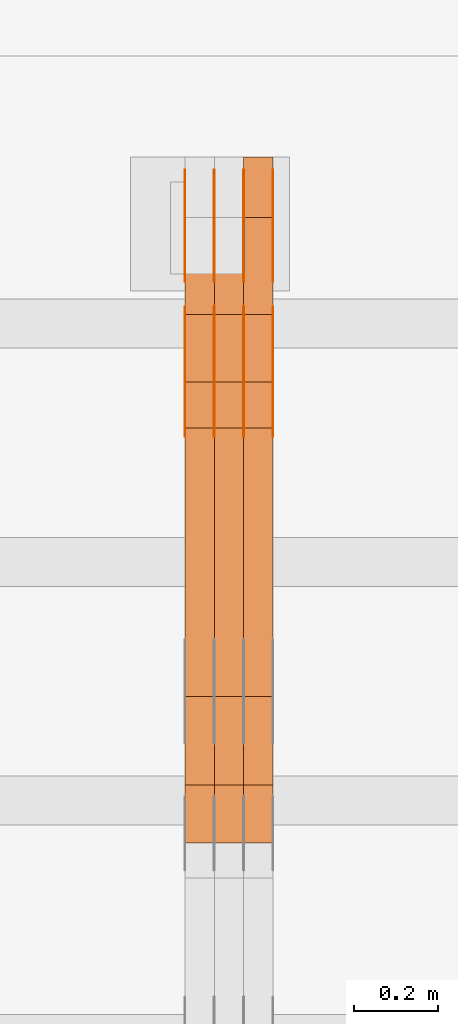
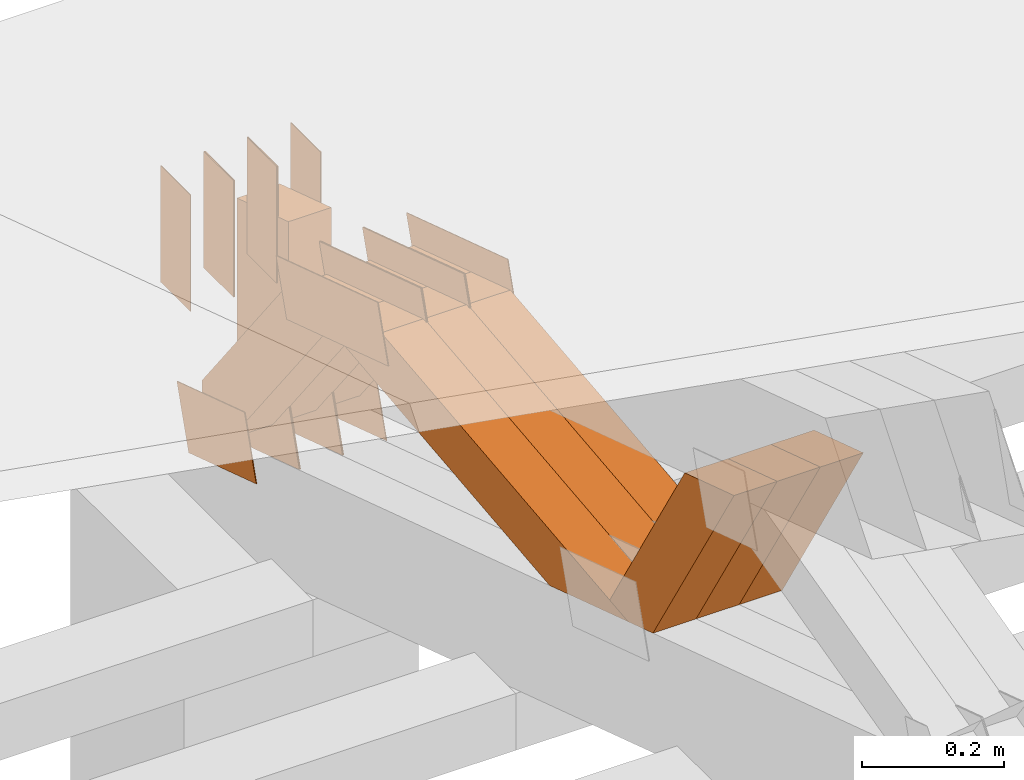
# One storey, part 222 of 385: 28 proxies.
"""IFC2X3 building model written with IfcOpenShell, lengths in millimetres."""

from ifc_helpers import new_model, entity, si_unit, converted_unit, derived_unit, direction, frame, frame_2d, origin, place, context, subcontext, project, spatial, polyline, rectangle, outline, extrude, source, transform, mapped, material, type_object, type_shapes, element, save


model = new_model("IFC2X3")

# Units and contexts
model_context = context("Model", 3, precision=0.01, world=origin(), true_north=direction((6.12303176911189e-17, 1.0)))
body_context = subcontext(model_context, "Body", "Model", "MODEL_VIEW")
ifc_project = project(units=[si_unit("LENGTHUNIT", "METRE", prefix="MILLI"), si_unit("AREAUNIT", "SQUARE_METRE"), si_unit("VOLUMEUNIT", "CUBIC_METRE"), converted_unit("PLANEANGLEUNIT", "DEGREE", entity("IfcRatioMeasure", 0.0174532925199433), si_unit("PLANEANGLEUNIT", "RADIAN"), dimensions=[0, 0, 0, 0, 0, 0, 0]), si_unit("MASSUNIT", "GRAM", prefix="KILO"), derived_unit("MASSDENSITYUNIT", [(si_unit("MASSUNIT", "GRAM", prefix="KILO"), 1), (si_unit("LENGTHUNIT", "METRE"), -3)]), si_unit("TIMEUNIT", "SECOND"), si_unit("FREQUENCYUNIT", "HERTZ"), si_unit("THERMODYNAMICTEMPERATUREUNIT", "DEGREE_CELSIUS"), derived_unit("THERMALTRANSMITTANCEUNIT", [(si_unit("MASSUNIT", "GRAM", prefix="KILO"), 1), (si_unit("THERMODYNAMICTEMPERATUREUNIT", "KELVIN"), -1), (si_unit("TIMEUNIT", "SECOND"), -3)]), derived_unit("VOLUMETRICFLOWRATEUNIT", [(si_unit("LENGTHUNIT", "METRE"), 3), (si_unit("TIMEUNIT", "SECOND"), -1)]), si_unit("ELECTRICCURRENTUNIT", "AMPERE"), si_unit("ELECTRICVOLTAGEUNIT", "VOLT"), si_unit("POWERUNIT", "WATT"), si_unit("FORCEUNIT", "NEWTON", prefix="KILO"), si_unit("ILLUMINANCEUNIT", "LUX"), si_unit("LUMINOUSFLUXUNIT", "LUMEN"), si_unit("LUMINOUSINTENSITYUNIT", "CANDELA"), derived_unit("USERDEFINED", [(si_unit("MASSUNIT", "GRAM", prefix="KILO"), -1), (si_unit("LENGTHUNIT", "METRE"), -2), (si_unit("TIMEUNIT", "SECOND"), 3), (si_unit("LUMINOUSFLUXUNIT", "LUMEN"), 1)]), derived_unit("LINEARVELOCITYUNIT", [(si_unit("LENGTHUNIT", "METRE"), 1), (si_unit("TIMEUNIT", "SECOND"), -1)]), si_unit("PRESSUREUNIT", "PASCAL"), derived_unit("USERDEFINED", [(si_unit("LENGTHUNIT", "METRE"), -2), (si_unit("MASSUNIT", "GRAM", prefix="KILO"), 1), (si_unit("TIMEUNIT", "SECOND"), -2)])], contexts=[model_context])

# Site, building, storey
site_placement = place(None, origin())
site = spatial("IfcSite", under=ifc_project, at=site_placement, CompositionType="ELEMENT")
building_placement = place(site_placement, origin())
building = spatial("IfcBuilding", under=site, at=building_placement, CompositionType="ELEMENT")
storey_placement = place(building_placement, origin())
storey = spatial("IfcBuildingStorey", under=building, at=storey_placement, Name="Default", CompositionType="ELEMENT", Elevation=0.0)

# Proxies
ifc_material_1 = material(Name="IfcSurfaceStyle #274926")
building_element_proxy_type_1 = type_object("IfcBuildingElementProxyType", PredefinedType="NOTDEFINED", material=ifc_material_1)
shared_shape_1 = source(origin(), body_context, "Body", "SweptSolid", [
    extrude(outline(polyline([(-100.000024997547, -54.0000105875654), (100.000088940899, -54.0000105875654), (99.9999100805868, 54.0000105875654), (-99.9999740239394, 54.0000105875654), (-100.000024997547, -54.0000105875654)])), frame((100.000088940899, 54.0000474633838, 0.0), z_axis=(0.0, 0.0, 1.0), x_axis=(-1.0, 0.0, 0.0)), (0.0, 0.0, 1.0), 1.3),
])
type_shapes(building_element_proxy_type_1, [shared_shape_1])
proxy_1_placement = place(building_placement, frame((21386.3, 26390.6212638563, 73.3227520411355), z_axis=(-1.0, 0.0, 0.0), x_axis=(0.0, -0.951056516295124, 0.309016994375039)))
element("IfcBuildingElementProxy", 1, at=proxy_1_placement, inside=storey, type_object=building_element_proxy_type_1, material=ifc_material_1, context=body_context, shape_type="MappedRepresentation", body=[
    mapped(shared_shape_1, transform((0.0, 0.0, 0.0), scale=1.0)),
])
ifc_material_2 = material(Name="IfcSurfaceStyle #274869")
building_element_proxy_type_2 = type_object("IfcBuildingElementProxyType", PredefinedType="NOTDEFINED", material=ifc_material_2)
shared_shape_2 = source(origin(), body_context, "Body", "SweptSolid", [
    extrude(outline(polyline([(-100.000024997547, -54.0000105875654), (100.000088940899, -54.0000105875654), (99.9999100805868, 54.0000105875654), (-99.9999740239394, 54.0000105875654), (-100.000024997547, -54.0000105875654)])), frame((100.000088940899, 54.0000474633838, 0.0), z_axis=(0.0, 0.0, 1.0), x_axis=(-1.0, 0.0, 0.0)), (0.0, 0.0, 1.0), 1.3),
])
type_shapes(building_element_proxy_type_2, [shared_shape_2])
proxy_2_placement = place(building_placement, frame((21315.0, 26390.6212638563, 73.3227520411355), z_axis=(-1.0, 0.0, 0.0), x_axis=(0.0, -0.951056516295124, 0.309016994375039)))
element("IfcBuildingElementProxy", 2, at=proxy_2_placement, inside=storey, type_object=building_element_proxy_type_2, material=ifc_material_2, context=body_context, shape_type="MappedRepresentation", body=[
    mapped(shared_shape_2, transform((0.0, 0.0, 0.0), scale=1.0)),
])
ifc_material_3 = material(Name="IfcSurfaceStyle #274812")
building_element_proxy_type_3 = type_object("IfcBuildingElementProxyType", PredefinedType="NOTDEFINED", material=ifc_material_3)
shared_shape_3 = source(origin(), body_context, "Body", "SweptSolid", [
    extrude(outline(polyline([(-100.000024997547, -54.0000105875654), (100.000088940899, -54.0000105875654), (99.9999100805868, 54.0000105875654), (-99.9999740239394, 54.0000105875654), (-100.000024997547, -54.0000105875654)])), frame((100.000088940899, 54.0000474633838, 0.0), z_axis=(0.0, 0.0, 1.0), x_axis=(-1.0, 0.0, 0.0)), (0.0, 0.0, 1.0), 1.3),
])
type_shapes(building_element_proxy_type_3, [shared_shape_3])
proxy_3_placement = place(building_placement, frame((21316.3, 26390.6212638563, 73.3227520411355), z_axis=(-1.0, 0.0, 0.0), x_axis=(0.0, -0.951056516295124, 0.309016994375039)))
element("IfcBuildingElementProxy", 3, at=proxy_3_placement, inside=storey, type_object=building_element_proxy_type_3, material=ifc_material_3, context=body_context, shape_type="MappedRepresentation", body=[
    mapped(shared_shape_3, transform((0.0, 0.0, 0.0), scale=1.0)),
])
ifc_material_4 = material(Name="IfcSurfaceStyle #274755")
building_element_proxy_type_4 = type_object("IfcBuildingElementProxyType", PredefinedType="NOTDEFINED", material=ifc_material_4)
shared_shape_4 = source(origin(), body_context, "Body", "SweptSolid", [
    extrude(outline(polyline([(-100.000024997547, -54.0000105875654), (100.000088940899, -54.0000105875654), (99.9999100805868, 54.0000105875654), (-99.9999740239394, 54.0000105875654), (-100.000024997547, -54.0000105875654)])), frame((100.000088940899, 54.0000474633838, 0.0), z_axis=(0.0, 0.0, 1.0), x_axis=(-1.0, 0.0, 0.0)), (0.0, 0.0, 1.0), 1.29999999999998),
])
type_shapes(building_element_proxy_type_4, [shared_shape_4])
proxy_4_placement = place(building_placement, frame((21245.0, 26390.6212638563, 73.3227520411355), z_axis=(-1.0, 0.0, 0.0), x_axis=(0.0, -0.951056516295124, 0.309016994375039)))
element("IfcBuildingElementProxy", 4, at=proxy_4_placement, inside=storey, type_object=building_element_proxy_type_4, material=ifc_material_4, context=body_context, shape_type="MappedRepresentation", body=[
    mapped(shared_shape_4, transform((0.0, 0.0, 0.0), scale=1.0)),
])
ifc_material_5 = material(Name="IfcSurfaceStyle #274698")
building_element_proxy_type_5 = type_object("IfcBuildingElementProxyType", PredefinedType="NOTDEFINED", material=ifc_material_5)
shared_shape_5 = source(origin(), body_context, "Body", "SweptSolid", [
    extrude(outline(polyline([(-100.000024997547, -54.0000105875654), (100.000088940899, -54.0000105875654), (99.9999100805868, 54.0000105875654), (-99.9999740239394, 54.0000105875654), (-100.000024997547, -54.0000105875654)])), frame((100.000088940899, 54.0000474633838, 0.0), z_axis=(0.0, 0.0, 1.0), x_axis=(-1.0, 0.0, 0.0)), (0.0, 0.0, 1.0), 1.29999999999998),
])
type_shapes(building_element_proxy_type_5, [shared_shape_5])
proxy_5_placement = place(building_placement, frame((21246.3, 26390.6212638563, 73.3227520411355), z_axis=(-1.0, 0.0, 0.0), x_axis=(0.0, -0.951056516295124, 0.309016994375039)))
element("IfcBuildingElementProxy", 5, at=proxy_5_placement, inside=storey, type_object=building_element_proxy_type_5, material=ifc_material_5, context=body_context, shape_type="MappedRepresentation", body=[
    mapped(shared_shape_5, transform((0.0, 0.0, 0.0), scale=1.0)),
])
ifc_material_6 = material(Name="IfcSurfaceStyle #274641")
building_element_proxy_type_6 = type_object("IfcBuildingElementProxyType", PredefinedType="NOTDEFINED", material=ifc_material_6)
shared_shape_6 = source(origin(), body_context, "Body", "SweptSolid", [
    extrude(outline(polyline([(-100.000024997547, -54.0000105875654), (100.000088940899, -54.0000105875654), (99.9999100805868, 54.0000105875654), (-99.9999740239394, 54.0000105875654), (-100.000024997547, -54.0000105875654)])), frame((100.000088940899, 54.0000474633838, 0.0), z_axis=(0.0, 0.0, 1.0), x_axis=(-1.0, 0.0, 0.0)), (0.0, 0.0, 1.0), 1.29999999999999),
])
type_shapes(building_element_proxy_type_6, [shared_shape_6])
proxy_6_placement = place(building_placement, frame((21175.0, 26390.6212638563, 73.3227520411355), z_axis=(-1.0, 0.0, 0.0), x_axis=(0.0, -0.951056516295124, 0.309016994375039)))
element("IfcBuildingElementProxy", 6, at=proxy_6_placement, inside=storey, type_object=building_element_proxy_type_6, material=ifc_material_6, context=body_context, shape_type="MappedRepresentation", body=[
    mapped(shared_shape_6, transform((0.0, 0.0, 0.0), scale=1.0)),
])
ifc_material_7 = material(Name="IfcSurfaceStyle #262272")
building_element_proxy_type_7 = type_object("IfcBuildingElementProxyType", PredefinedType="NOTDEFINED", material=ifc_material_7)
shared_shape_7 = source(origin(), body_context, "Body", "SweptSolid", [
    extrude(outline(polyline([(-149.999901061401, -48.0000057587028), (150.000035297123, -48.0000057587028), (149.999910491851, 48.0000057587028), (-150.000044727574, 48.0000057587028), (-149.999901061401, -48.0000057587028)])), frame((150.000035297123, 48.0000632585775, 0.0), z_axis=(0.0, 0.0, 1.0), x_axis=(-1.0, 0.0, 0.0)), (0.0, 0.0, 1.0), 1.29999999999999),
])
type_shapes(building_element_proxy_type_7, [shared_shape_7])
proxy_7_placement = place(building_placement, frame((21386.3, 26115.0176968219, 469.58296924555), z_axis=(-1.0, 0.0, 0.0), x_axis=(0.0, -0.951056516295154, 0.309016994374948)))
element("IfcBuildingElementProxy", 7, at=proxy_7_placement, inside=storey, type_object=building_element_proxy_type_7, material=ifc_material_7, context=body_context, shape_type="MappedRepresentation", body=[
    mapped(shared_shape_7, transform((0.0, 0.0, 0.0), scale=1.0)),
])
ifc_material_8 = material(Name="IfcSurfaceStyle #262215")
building_element_proxy_type_8 = type_object("IfcBuildingElementProxyType", PredefinedType="NOTDEFINED", material=ifc_material_8)
shared_shape_8 = source(origin(), body_context, "Body", "SweptSolid", [
    extrude(outline(polyline([(-149.999901061401, -48.0000057587028), (150.000035297123, -48.0000057587028), (149.999910491851, 48.0000057587028), (-150.000044727574, 48.0000057587028), (-149.999901061401, -48.0000057587028)])), frame((150.000035297123, 48.0000632585775, 0.0), z_axis=(0.0, 0.0, 1.0), x_axis=(-1.0, 0.0, 0.0)), (0.0, 0.0, 1.0), 1.29999999999999),
])
type_shapes(building_element_proxy_type_8, [shared_shape_8])
proxy_8_placement = place(building_placement, frame((21315.0, 26115.0176968219, 469.58296924555), z_axis=(-1.0, 0.0, 0.0), x_axis=(0.0, -0.951056516295154, 0.309016994374948)))
element("IfcBuildingElementProxy", 8, at=proxy_8_placement, inside=storey, type_object=building_element_proxy_type_8, material=ifc_material_8, context=body_context, shape_type="MappedRepresentation", body=[
    mapped(shared_shape_8, transform((0.0, 0.0, 0.0), scale=1.0)),
])
ifc_material_9 = material(Name="IfcSurfaceStyle #262158")
building_element_proxy_type_9 = type_object("IfcBuildingElementProxyType", PredefinedType="NOTDEFINED", material=ifc_material_9)
shared_shape_9 = source(origin(), body_context, "Body", "SweptSolid", [
    extrude(outline(polyline([(-149.999901061401, -48.0000057587028), (150.000035297123, -48.0000057587028), (149.999910491851, 48.0000057587028), (-150.000044727574, 48.0000057587028), (-149.999901061401, -48.0000057587028)])), frame((150.000035297123, 48.0000632585775, 0.0), z_axis=(0.0, 0.0, 1.0), x_axis=(-1.0, 0.0, 0.0)), (0.0, 0.0, 1.0), 1.29999999999999),
])
type_shapes(building_element_proxy_type_9, [shared_shape_9])
proxy_9_placement = place(building_placement, frame((21316.3, 26115.0176968219, 469.58296924555), z_axis=(-1.0, 0.0, 0.0), x_axis=(0.0, -0.951056516295154, 0.309016994374948)))
element("IfcBuildingElementProxy", 9, at=proxy_9_placement, inside=storey, type_object=building_element_proxy_type_9, material=ifc_material_9, context=body_context, shape_type="MappedRepresentation", body=[
    mapped(shared_shape_9, transform((0.0, 0.0, 0.0), scale=1.0)),
])
ifc_material_10 = material(Name="IfcSurfaceStyle #262101")
building_element_proxy_type_10 = type_object("IfcBuildingElementProxyType", PredefinedType="NOTDEFINED", material=ifc_material_10)
shared_shape_10 = source(origin(), body_context, "Body", "SweptSolid", [
    extrude(outline(polyline([(-149.999901061401, -48.0000057587028), (150.000035297123, -48.0000057587028), (149.999910491851, 48.0000057587028), (-150.000044727574, 48.0000057587028), (-149.999901061401, -48.0000057587028)])), frame((150.000035297123, 48.0000632585775, 0.0), z_axis=(0.0, 0.0, 1.0), x_axis=(-1.0, 0.0, 0.0)), (0.0, 0.0, 1.0), 1.29999999999998),
])
type_shapes(building_element_proxy_type_10, [shared_shape_10])
proxy_10_placement = place(building_placement, frame((21245.0, 26115.0176968219, 469.58296924555), z_axis=(-1.0, 0.0, 0.0), x_axis=(0.0, -0.951056516295154, 0.309016994374948)))
element("IfcBuildingElementProxy", 10, at=proxy_10_placement, inside=storey, type_object=building_element_proxy_type_10, material=ifc_material_10, context=body_context, shape_type="MappedRepresentation", body=[
    mapped(shared_shape_10, transform((0.0, 0.0, 0.0), scale=1.0)),
])
ifc_material_11 = material(Name="IfcSurfaceStyle #262044")
building_element_proxy_type_11 = type_object("IfcBuildingElementProxyType", PredefinedType="NOTDEFINED", material=ifc_material_11)
shared_shape_11 = source(origin(), body_context, "Body", "SweptSolid", [
    extrude(outline(polyline([(-149.999901061401, -48.0000057587028), (150.000035297123, -48.0000057587028), (149.999910491851, 48.0000057587028), (-150.000044727574, 48.0000057587028), (-149.999901061401, -48.0000057587028)])), frame((150.000035297123, 48.0000632585775, 0.0), z_axis=(0.0, 0.0, 1.0), x_axis=(-1.0, 0.0, 0.0)), (0.0, 0.0, 1.0), 1.29999999999998),
])
type_shapes(building_element_proxy_type_11, [shared_shape_11])
proxy_11_placement = place(building_placement, frame((21246.3, 26115.0176968219, 469.58296924555), z_axis=(-1.0, 0.0, 0.0), x_axis=(0.0, -0.951056516295154, 0.309016994374948)))
element("IfcBuildingElementProxy", 11, at=proxy_11_placement, inside=storey, type_object=building_element_proxy_type_11, material=ifc_material_11, context=body_context, shape_type="MappedRepresentation", body=[
    mapped(shared_shape_11, transform((0.0, 0.0, 0.0), scale=1.0)),
])
ifc_material_12 = material(Name="IfcSurfaceStyle #261987")
building_element_proxy_type_12 = type_object("IfcBuildingElementProxyType", PredefinedType="NOTDEFINED", material=ifc_material_12)
shared_shape_12 = source(origin(), body_context, "Body", "SweptSolid", [
    extrude(outline(polyline([(-149.999901061401, -48.0000057587028), (150.000035297123, -48.0000057587028), (149.999910491851, 48.0000057587028), (-150.000044727574, 48.0000057587028), (-149.999901061401, -48.0000057587028)])), frame((150.000035297123, 48.0000632585775, 0.0), z_axis=(0.0, 0.0, 1.0), x_axis=(-1.0, 0.0, 0.0)), (0.0, 0.0, 1.0), 1.29999999999998),
])
type_shapes(building_element_proxy_type_12, [shared_shape_12])
proxy_12_placement = place(building_placement, frame((21175.0, 26115.0176968219, 469.58296924555), z_axis=(-1.0, 0.0, 0.0), x_axis=(0.0, -0.951056516295154, 0.309016994374948)))
element("IfcBuildingElementProxy", 12, at=proxy_12_placement, inside=storey, type_object=building_element_proxy_type_12, material=ifc_material_12, context=body_context, shape_type="MappedRepresentation", body=[
    mapped(shared_shape_12, transform((0.0, 0.0, 0.0), scale=1.0)),
])
ifc_material_13 = material(Name="IfcSurfaceStyle #261930")
building_element_proxy_type_13 = type_object("IfcBuildingElementProxyType", PredefinedType="NOTDEFINED", material=ifc_material_13)
shared_shape_13 = source(origin(), body_context, "Body", "SweptSolid", [
    extrude(rectangle(XDim=200.0, YDim=84.0000000000005, at=frame_2d((-2.1316282072803e-14, 1.06581410364015e-14), x_axis=(1.0, 0.0))), frame((100.0, 42.0, 0.0), z_axis=(0.0, 0.0, 1.0), x_axis=(-1.0, 0.0, 0.0)), (0.0, 0.0, 1.0), 1.3),
])
type_shapes(building_element_proxy_type_13, [shared_shape_13])
proxy_13_placement = place(building_placement, frame((21386.3, 26469.5000000002, 518.521545410156), z_axis=(-1.0, 0.0, 0.0), x_axis=(0.0, 0.0, -1.0)))
element("IfcBuildingElementProxy", 13, at=proxy_13_placement, inside=storey, type_object=building_element_proxy_type_13, material=ifc_material_13, context=body_context, shape_type="MappedRepresentation", body=[
    mapped(shared_shape_13, transform((0.0, 0.0, 0.0), scale=1.0)),
])
ifc_material_14 = material(Name="IfcSurfaceStyle #261873")
building_element_proxy_type_14 = type_object("IfcBuildingElementProxyType", PredefinedType="NOTDEFINED", material=ifc_material_14)
shared_shape_14 = source(origin(), body_context, "Body", "SweptSolid", [
    extrude(rectangle(XDim=200.0, YDim=84.0000000000005, at=frame_2d((-2.1316282072803e-14, 1.06581410364015e-14), x_axis=(1.0, 0.0))), frame((100.0, 42.0, 0.0), z_axis=(0.0, 0.0, 1.0), x_axis=(-1.0, 0.0, 0.0)), (0.0, 0.0, 1.0), 1.3),
])
type_shapes(building_element_proxy_type_14, [shared_shape_14])
proxy_14_placement = place(building_placement, frame((21315.0, 26469.5000000002, 518.521545410156), z_axis=(-1.0, 0.0, 0.0), x_axis=(0.0, 0.0, -1.0)))
element("IfcBuildingElementProxy", 14, at=proxy_14_placement, inside=storey, type_object=building_element_proxy_type_14, material=ifc_material_14, context=body_context, shape_type="MappedRepresentation", body=[
    mapped(shared_shape_14, transform((0.0, 0.0, 0.0), scale=1.0)),
])
ifc_material_15 = material(Name="IfcSurfaceStyle #261816")
building_element_proxy_type_15 = type_object("IfcBuildingElementProxyType", PredefinedType="NOTDEFINED", material=ifc_material_15)
shared_shape_15 = source(origin(), body_context, "Body", "SweptSolid", [
    extrude(rectangle(XDim=200.0, YDim=84.0000000000005, at=frame_2d((-2.1316282072803e-14, 1.06581410364015e-14), x_axis=(1.0, 0.0))), frame((100.0, 42.0, 0.0), z_axis=(0.0, 0.0, 1.0), x_axis=(-1.0, 0.0, 0.0)), (0.0, 0.0, 1.0), 1.3),
])
type_shapes(building_element_proxy_type_15, [shared_shape_15])
proxy_15_placement = place(building_placement, frame((21316.3, 26469.5000000002, 518.521545410156), z_axis=(-1.0, 0.0, 0.0), x_axis=(0.0, 0.0, -1.0)))
element("IfcBuildingElementProxy", 15, at=proxy_15_placement, inside=storey, type_object=building_element_proxy_type_15, material=ifc_material_15, context=body_context, shape_type="MappedRepresentation", body=[
    mapped(shared_shape_15, transform((0.0, 0.0, 0.0), scale=1.0)),
])
ifc_material_16 = material(Name="IfcSurfaceStyle #261759")
building_element_proxy_type_16 = type_object("IfcBuildingElementProxyType", PredefinedType="NOTDEFINED", material=ifc_material_16)
shared_shape_16 = source(origin(), body_context, "Body", "SweptSolid", [
    extrude(rectangle(XDim=200.0, YDim=84.0000000000005, at=frame_2d((-2.1316282072803e-14, 1.06581410364015e-14), x_axis=(1.0, 0.0))), frame((100.0, 42.0, 0.0), z_axis=(0.0, 0.0, 1.0), x_axis=(-1.0, 0.0, 0.0)), (0.0, 0.0, 1.0), 1.29999999999998),
])
type_shapes(building_element_proxy_type_16, [shared_shape_16])
proxy_16_placement = place(building_placement, frame((21245.0, 26469.5000000002, 518.521545410156), z_axis=(-1.0, 0.0, 0.0), x_axis=(0.0, 0.0, -1.0)))
element("IfcBuildingElementProxy", 16, at=proxy_16_placement, inside=storey, type_object=building_element_proxy_type_16, material=ifc_material_16, context=body_context, shape_type="MappedRepresentation", body=[
    mapped(shared_shape_16, transform((0.0, 0.0, 0.0), scale=1.0)),
])
ifc_material_17 = material(Name="IfcSurfaceStyle #261702")
building_element_proxy_type_17 = type_object("IfcBuildingElementProxyType", PredefinedType="NOTDEFINED", material=ifc_material_17)
shared_shape_17 = source(origin(), body_context, "Body", "SweptSolid", [
    extrude(rectangle(XDim=200.0, YDim=84.0000000000005, at=frame_2d((-2.1316282072803e-14, 1.06581410364015e-14), x_axis=(1.0, 0.0))), frame((100.0, 42.0, 0.0), z_axis=(0.0, 0.0, 1.0), x_axis=(-1.0, 0.0, 0.0)), (0.0, 0.0, 1.0), 1.29999999999998),
])
type_shapes(building_element_proxy_type_17, [shared_shape_17])
proxy_17_placement = place(building_placement, frame((21246.3, 26469.5000000002, 518.521545410156), z_axis=(-1.0, 0.0, 0.0), x_axis=(0.0, 0.0, -1.0)))
element("IfcBuildingElementProxy", 17, at=proxy_17_placement, inside=storey, type_object=building_element_proxy_type_17, material=ifc_material_17, context=body_context, shape_type="MappedRepresentation", body=[
    mapped(shared_shape_17, transform((0.0, 0.0, 0.0), scale=1.0)),
])
ifc_material_18 = material(Name="IfcSurfaceStyle #261645")
building_element_proxy_type_18 = type_object("IfcBuildingElementProxyType", PredefinedType="NOTDEFINED", material=ifc_material_18)
shared_shape_18 = source(origin(), body_context, "Body", "SweptSolid", [
    extrude(rectangle(XDim=200.0, YDim=84.0000000000005, at=frame_2d((-2.1316282072803e-14, 1.06581410364015e-14), x_axis=(1.0, 0.0))), frame((100.0, 42.0, 0.0), z_axis=(0.0, 0.0, 1.0), x_axis=(-1.0, 0.0, 0.0)), (0.0, 0.0, 1.0), 1.29999999999999),
])
type_shapes(building_element_proxy_type_18, [shared_shape_18])
proxy_18_placement = place(building_placement, frame((21175.0, 26469.5000000002, 518.521545410156), z_axis=(-1.0, 0.0, 0.0), x_axis=(0.0, 0.0, -1.0)))
element("IfcBuildingElementProxy", 18, at=proxy_18_placement, inside=storey, type_object=building_element_proxy_type_18, material=ifc_material_18, context=body_context, shape_type="MappedRepresentation", body=[
    mapped(shared_shape_18, transform((0.0, 0.0, 0.0), scale=1.0)),
])
ifc_material_19 = material(Name="IfcSurfaceStyle #250914")
building_element_proxy_type_19 = type_object("IfcBuildingElementProxyType", Name="T1-W31 250912", PredefinedType="NOTDEFINED", material=ifc_material_19)
shared_shape_19 = source(origin(), body_context, "Body", "SweptSolid", [
    extrude(outline(polyline([(-201.245318299844, -47.5000121670808), (204.413774229459, -47.5000121670808), (182.034306640891, 5.35692244583164e-05), (126.70380769348, 47.4999853824686), (-311.906570263987, 47.4999853824686), (-201.245318299844, -47.5000121670808)])), frame((204.413774229459, 47.5002684334588, 0.0), z_axis=(0.0, 0.0, 1.0), x_axis=(-1.0, 0.0, 0.0)), (0.0, 0.0, 1.0), 70.0),
])
type_shapes(building_element_proxy_type_19, [shared_shape_19])
proxy_19_placement = place(building_placement, frame((21385.0, 25127.5652647985, 487.27008059185), z_axis=(-1.0, 0.0, 0.0), x_axis=(0.0, -0.520333970303023, 0.853962855953755)))
element("IfcBuildingElementProxy", 19, at=proxy_19_placement, inside=storey, type_object=building_element_proxy_type_19, material=ifc_material_19, Name="T1-W31", context=body_context, shape_type="MappedRepresentation", body=[
    mapped(shared_shape_19, transform((0.0, 0.0, 0.0), scale=1.0)),
])
ifc_material_20 = material(Name="IfcSurfaceStyle #250848")
building_element_proxy_type_20 = type_object("IfcBuildingElementProxyType", Name="T1-W31 250846", PredefinedType="NOTDEFINED", material=ifc_material_20)
shared_shape_20 = source(origin(), body_context, "Body", "SweptSolid", [
    extrude(outline(polyline([(-201.245318299844, -47.5000121670808), (204.413774229459, -47.5000121670808), (182.034306640891, 5.35692244583164e-05), (126.70380769348, 47.4999853824686), (-311.906570263987, 47.4999853824686), (-201.245318299844, -47.5000121670808)])), frame((204.413774229459, 47.5002684334588, 0.0), z_axis=(0.0, 0.0, 1.0), x_axis=(-1.0, 0.0, 0.0)), (0.0, 0.0, 1.0), 70.0),
])
type_shapes(building_element_proxy_type_20, [shared_shape_20])
proxy_20_placement = place(building_placement, frame((21315.0, 25127.5652647985, 487.27008059185), z_axis=(-1.0, 0.0, 0.0), x_axis=(0.0, -0.520333970303023, 0.853962855953755)))
element("IfcBuildingElementProxy", 20, at=proxy_20_placement, inside=storey, type_object=building_element_proxy_type_20, material=ifc_material_20, Name="T1-W31", context=body_context, shape_type="MappedRepresentation", body=[
    mapped(shared_shape_20, transform((0.0, 0.0, 0.0), scale=1.0)),
])
ifc_material_21 = material(Name="IfcSurfaceStyle #250782")
building_element_proxy_type_21 = type_object("IfcBuildingElementProxyType", Name="T1-W31 250780", PredefinedType="NOTDEFINED", material=ifc_material_21)
shared_shape_21 = source(origin(), body_context, "Body", "SweptSolid", [
    extrude(outline(polyline([(-201.245318299844, -47.5000121670808), (204.413774229459, -47.5000121670808), (182.034306640891, 5.35692244583164e-05), (126.70380769348, 47.4999853824686), (-311.906570263987, 47.4999853824686), (-201.245318299844, -47.5000121670808)])), frame((204.413774229459, 47.5002684334588, 0.0), z_axis=(0.0, 0.0, 1.0), x_axis=(-1.0, 0.0, 0.0)), (0.0, 0.0, 1.0), 70.0),
])
type_shapes(building_element_proxy_type_21, [shared_shape_21])
proxy_21_placement = place(building_placement, frame((21245.0, 25127.5652647985, 487.27008059185), z_axis=(-1.0, 0.0, 0.0), x_axis=(0.0, -0.520333970303023, 0.853962855953755)))
element("IfcBuildingElementProxy", 21, at=proxy_21_placement, inside=storey, type_object=building_element_proxy_type_21, material=ifc_material_21, Name="T1-W31", context=body_context, shape_type="MappedRepresentation", body=[
    mapped(shared_shape_21, transform((0.0, 0.0, 0.0), scale=1.0)),
])
ifc_material_22 = material(Name="IfcSurfaceStyle #250518")
building_element_proxy_type_22 = type_object("IfcBuildingElementProxyType", Name="T1-W4 250516", PredefinedType="NOTDEFINED", material=ifc_material_22)
shared_shape_22 = source(origin(), body_context, "Body", "SweptSolid", [
    extrude(outline(polyline([(-510.077325435179, -47.4999981284922), (188.854793418912, -47.4999981284922), (294.906688207675, 1.67015383116809e-05), (324.289382923648, 47.499989777723), (-297.973539115057, 47.4999897777231), (-510.077325435179, -47.4999981284922)])), frame((324.289382923648, 47.5000278316275, 0.0), z_axis=(0.0, 0.0, 1.0), x_axis=(-1.0, 0.0, 0.0)), (0.0, 0.0, 1.0), 70.0),
])
type_shapes(building_element_proxy_type_22, [shared_shape_22])
proxy_22_placement = place(building_placement, frame((21385.0, 25996.2241251556, 525.69905884318), z_axis=(-1.0, 0.0, 0.0), x_axis=(0.0, -0.994287125203057, -0.106738524701444)))
element("IfcBuildingElementProxy", 22, at=proxy_22_placement, inside=storey, type_object=building_element_proxy_type_22, material=ifc_material_22, Name="T1-W4", context=body_context, shape_type="MappedRepresentation", body=[
    mapped(shared_shape_22, transform((0.0, 0.0, 0.0), scale=1.0)),
])
ifc_material_23 = material(Name="IfcSurfaceStyle #250452")
building_element_proxy_type_23 = type_object("IfcBuildingElementProxyType", Name="T1-W4 250450", PredefinedType="NOTDEFINED", material=ifc_material_23)
shared_shape_23 = source(origin(), body_context, "Body", "SweptSolid", [
    extrude(outline(polyline([(-510.077325435179, -47.4999981284922), (188.854793418912, -47.4999981284922), (294.906688207675, 1.67015383116809e-05), (324.289382923648, 47.499989777723), (-297.973539115057, 47.4999897777231), (-510.077325435179, -47.4999981284922)])), frame((324.289382923648, 47.5000278316275, 0.0), z_axis=(0.0, 0.0, 1.0), x_axis=(-1.0, 0.0, 0.0)), (0.0, 0.0, 1.0), 70.0),
])
type_shapes(building_element_proxy_type_23, [shared_shape_23])
proxy_23_placement = place(building_placement, frame((21315.0, 25996.2241251556, 525.69905884318), z_axis=(-1.0, 0.0, 0.0), x_axis=(0.0, -0.994287125203057, -0.106738524701444)))
element("IfcBuildingElementProxy", 23, at=proxy_23_placement, inside=storey, type_object=building_element_proxy_type_23, material=ifc_material_23, Name="T1-W4", context=body_context, shape_type="MappedRepresentation", body=[
    mapped(shared_shape_23, transform((0.0, 0.0, 0.0), scale=1.0)),
])
ifc_material_24 = material(Name="IfcSurfaceStyle #250386")
building_element_proxy_type_24 = type_object("IfcBuildingElementProxyType", Name="T1-W4 250384", PredefinedType="NOTDEFINED", material=ifc_material_24)
shared_shape_24 = source(origin(), body_context, "Body", "SweptSolid", [
    extrude(outline(polyline([(-510.077325435179, -47.4999981284922), (188.854793418912, -47.4999981284922), (294.906688207675, 1.67015383116809e-05), (324.289382923648, 47.499989777723), (-297.973539115057, 47.4999897777231), (-510.077325435179, -47.4999981284922)])), frame((324.289382923648, 47.5000278316275, 0.0), z_axis=(0.0, 0.0, 1.0), x_axis=(-1.0, 0.0, 0.0)), (0.0, 0.0, 1.0), 70.0),
])
type_shapes(building_element_proxy_type_24, [shared_shape_24])
proxy_24_placement = place(building_placement, frame((21245.0, 25996.2241251556, 525.69905884318), z_axis=(-1.0, 0.0, 0.0), x_axis=(0.0, -0.994287125203057, -0.106738524701444)))
element("IfcBuildingElementProxy", 24, at=proxy_24_placement, inside=storey, type_object=building_element_proxy_type_24, material=ifc_material_24, Name="T1-W4", context=body_context, shape_type="MappedRepresentation", body=[
    mapped(shared_shape_24, transform((0.0, 0.0, 0.0), scale=1.0)),
])
ifc_material_25 = material(Name="IfcSurfaceStyle #250122")
building_element_proxy_type_25 = type_object("IfcBuildingElementProxyType", Name="T1-W21 250120", PredefinedType="NOTDEFINED", material=ifc_material_25)
shared_shape_25 = source(origin(), body_context, "Body", "SweptSolid", [
    extrude(outline(polyline([(-209.199362597501, -47.5000308982766), (168.813164734153, -47.5000308982766), (229.900717355638, -2.18385470334148e-05), (159.828709317766, 47.5000418175501), (-349.343228810055, 47.5000418175502), (-209.199362597501, -47.5000308982766)])), frame((229.900720156071, 47.5000418175501, 0.0), z_axis=(0.0, 0.0, 1.0), x_axis=(-1.0, 0.0, 0.0)), (0.0, 0.0, 1.0), 70.0),
])
type_shapes(building_element_proxy_type_25, [shared_shape_25])
proxy_25_placement = place(building_placement, frame((21385.0, 26317.5019908272, 112.518372832984), z_axis=(-1.0, 0.0, 0.0), x_axis=(0.0, -0.613839629272042, 0.789430750310097)))
element("IfcBuildingElementProxy", 25, at=proxy_25_placement, inside=storey, type_object=building_element_proxy_type_25, material=ifc_material_25, Name="T1-W21", context=body_context, shape_type="MappedRepresentation", body=[
    mapped(shared_shape_25, transform((0.0, 0.0, 0.0), scale=1.0)),
])
ifc_material_26 = material(Name="IfcSurfaceStyle #250056")
building_element_proxy_type_26 = type_object("IfcBuildingElementProxyType", Name="T1-W21 250054", PredefinedType="NOTDEFINED", material=ifc_material_26)
shared_shape_26 = source(origin(), body_context, "Body", "SweptSolid", [
    extrude(outline(polyline([(-209.199362597501, -47.5000308982766), (168.813164734153, -47.5000308982766), (229.900717355638, -2.18385470334148e-05), (159.828709317766, 47.5000418175501), (-349.343228810055, 47.5000418175502), (-209.199362597501, -47.5000308982766)])), frame((229.900720156071, 47.5000418175501, 0.0), z_axis=(0.0, 0.0, 1.0), x_axis=(-1.0, 0.0, 0.0)), (0.0, 0.0, 1.0), 70.0),
])
type_shapes(building_element_proxy_type_26, [shared_shape_26])
proxy_26_placement = place(building_placement, frame((21315.0, 26317.5019908272, 112.518372832984), z_axis=(-1.0, 0.0, 0.0), x_axis=(0.0, -0.613839629272042, 0.789430750310097)))
element("IfcBuildingElementProxy", 26, at=proxy_26_placement, inside=storey, type_object=building_element_proxy_type_26, material=ifc_material_26, Name="T1-W21", context=body_context, shape_type="MappedRepresentation", body=[
    mapped(shared_shape_26, transform((0.0, 0.0, 0.0), scale=1.0)),
])
ifc_material_27 = material(Name="IfcSurfaceStyle #249990")
building_element_proxy_type_27 = type_object("IfcBuildingElementProxyType", Name="T1-W21 249988", PredefinedType="NOTDEFINED", material=ifc_material_27)
shared_shape_27 = source(origin(), body_context, "Body", "SweptSolid", [
    extrude(outline(polyline([(-209.199362597501, -47.5000308982766), (168.813164734153, -47.5000308982766), (229.900717355638, -2.18385470334148e-05), (159.828709317766, 47.5000418175501), (-349.343228810055, 47.5000418175502), (-209.199362597501, -47.5000308982766)])), frame((229.900720156071, 47.5000418175501, 0.0), z_axis=(0.0, 0.0, 1.0), x_axis=(-1.0, 0.0, 0.0)), (0.0, 0.0, 1.0), 70.0),
])
type_shapes(building_element_proxy_type_27, [shared_shape_27])
proxy_27_placement = place(building_placement, frame((21245.0, 26317.5019908272, 112.518372832984), z_axis=(-1.0, 0.0, 0.0), x_axis=(0.0, -0.613839629272042, 0.789430750310097)))
element("IfcBuildingElementProxy", 27, at=proxy_27_placement, inside=storey, type_object=building_element_proxy_type_27, material=ifc_material_27, Name="T1-W21", context=body_context, shape_type="MappedRepresentation", body=[
    mapped(shared_shape_27, transform((0.0, 0.0, 0.0), scale=1.0)),
])
ifc_material_28 = material(Name="IfcSurfaceStyle #249555")
building_element_proxy_type_28 = type_object("IfcBuildingElementProxyType", Name="T1-E2 249553", PredefinedType="NOTDEFINED", material=ifc_material_28)
shared_shape_28 = source(origin(), body_context, "Body", "SweptSolid", [
    extrude(outline(polyline([(-126.644535064697, -72.4999999999998), (173.757884979248, -72.4999999999998), (126.644542694092, 72.4999999999998), (-173.757892608642, 72.4999999999998), (-126.644535064697, -72.4999999999998)])), frame((173.757890653796, 72.5000000000002, 0.0), z_axis=(0.0, 0.0, 1.0), x_axis=(-1.0, 0.0, 0.0)), (0.0, 0.0, 1.0), 70.0),
])
type_shapes(building_element_proxy_type_28, [shared_shape_28])
proxy_28_placement = place(building_placement, frame((21385.0, 26500.0, 442.078222227283), z_axis=(-1.0, 0.0, 0.0), x_axis=(0.0, 0.0, -1.0)))
element("IfcBuildingElementProxy", 28, at=proxy_28_placement, inside=storey, type_object=building_element_proxy_type_28, material=ifc_material_28, Name="T1-E2", context=body_context, shape_type="MappedRepresentation", body=[
    mapped(shared_shape_28, transform((0.0, 0.0, 0.0), scale=1.0)),
])

save(model, "model.ifc")
